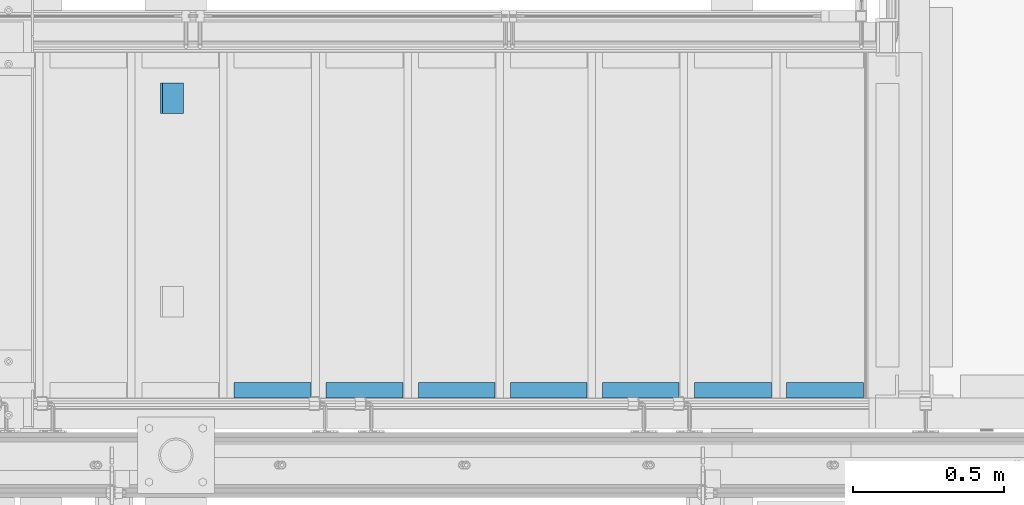
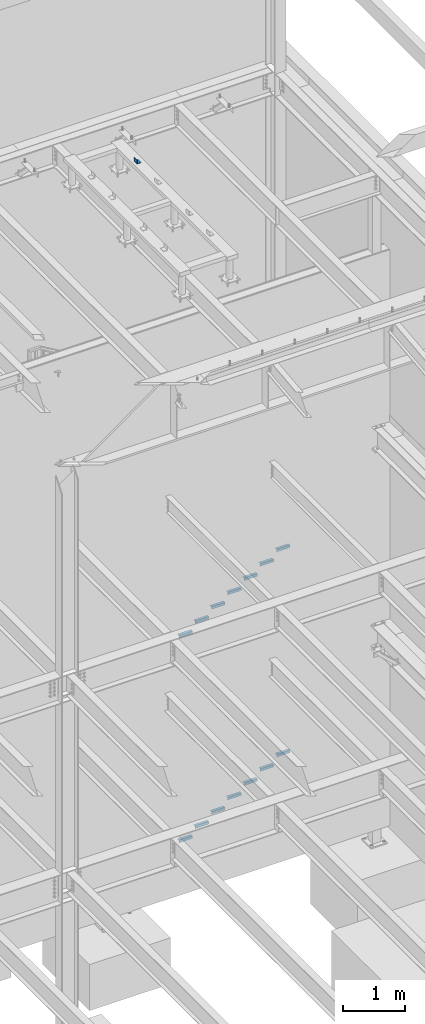
# One storey, part 914 of 1179: 15 beams, 3 elements without a shape of their own.
"""IFC2X3 building model written with IfcOpenShell, lengths in millimetres."""

from ifc_helpers import new_model, si_unit, frame, origin_with_axes, place, context, subcontext, project, spatial, faceted_brep, material, type_object, element, aggregate, save


model = new_model("IFC2X3")

# Units and contexts
model_context = context("Model", 3, precision=1e-05, world=origin_with_axes())
body_context = subcontext(model_context, "Body", "Model", "MODEL_VIEW")
ifc_project = project(units=[si_unit("LENGTHUNIT", "METRE", prefix="MILLI"), si_unit("AREAUNIT", "SQUARE_METRE"), si_unit("VOLUMEUNIT", "CUBIC_METRE"), si_unit("MASSUNIT", "GRAM", prefix="KILO"), si_unit("TIMEUNIT", "SECOND"), si_unit("PLANEANGLEUNIT", "RADIAN"), si_unit("SOLIDANGLEUNIT", "STERADIAN"), si_unit("THERMODYNAMICTEMPERATUREUNIT", "DEGREE_CELSIUS"), si_unit("LUMINOUSINTENSITYUNIT", "LUMEN")], contexts=[model_context])

# Site, building, storey
site_placement = place(None, origin_with_axes())
site = spatial("IfcSite", under=ifc_project, at=site_placement, CompositionType="ELEMENT")
building_placement = place(site_placement, origin_with_axes())
building = spatial("IfcBuilding", under=site, at=building_placement, Name="Undefined", CompositionType="ELEMENT")
storey_placement = place(building_placement, origin_with_axes())
storey = spatial("IfcBuildingStorey", under=building, at=storey_placement, Name="Undefined", CompositionType="ELEMENT", Elevation=0.0)

# Assembly, beams
assembly_1_placement = place(storey_placement, origin_with_axes())
assembly_1 = element("IfcElementAssembly", 1, at=assembly_1_placement, inside=storey, Name="STAIR", AssemblyPlace="NOTDEFINED", PredefinedType="RIGID_FRAME")
ifc_material = material(Name="STEEL/A36")
beam_type_1 = type_object("IfcBeamType", Name="L2X2X3/16", PredefinedType="NOTDEFINED")
beam_1_placement = place(assembly_1_placement, frame((22850.8130333856, 38233.3500001282, 5934.67030000019), z_axis=(0.0, 1.0, 0.0), x_axis=(-1.0, 0.0, 0.0)))
beam_1 = element("IfcBeam", 2, at=beam_1_placement, type_object=beam_type_1, material=ifc_material, Name="ANGLE", ObjectType="L2X2X3/16", context=body_context, shape_type="Brep", body=[
    faceted_brep([(0.0, 25.3999999999996, -25.4000000000015), (0.0, 25.3999999999996, 25.4000000000015), (254.0, 25.3999999999996, 25.4000000000001), (254.0, 25.3999999999996, -25.4000000000001), (0.0, 20.6374999999998, 25.4000000000015), (254.0, 20.6374999999998, 25.4000000000001), (0.0, 20.6374999999998, -20.6374999999971), (254.0, 20.6374999999998, -20.6374999999998), (0.0, -25.3999999999996, -20.6374999999971), (254.0, -25.3999999999996, -20.6374999999998), (0.0, -25.3999999999996, -25.4000000000015), (254.0, -25.3999999999996, -25.4000000000001)], [[[0, 1, 2, 3]], [[1, 4, 5, 2]], [[4, 6, 7, 5]], [[6, 8, 9, 7]], [[8, 10, 11, 9]], [[10, 0, 3, 11]], [[5, 7, 9, 11, 3, 2]], [[10, 8, 6, 4, 1, 0]]]),
])
beam_2_placement = place(assembly_1_placement, frame((22546.0130334085, 38233.3500001282, 5756.87030000019), z_axis=(0.0, 1.0, 0.0), x_axis=(-1.0, 0.0, 0.0)))
beam_2 = element("IfcBeam", 3, at=beam_2_placement, type_object=beam_type_1, material=ifc_material, Name="ANGLE", ObjectType="L2X2X3/16", context=body_context, shape_type="Brep", body=[
    faceted_brep([(0.0, 25.3999999999996, -25.4000000000015), (0.0, 25.3999999999996, 25.4000000000015), (254.0, 25.3999999999996, 25.4000000000001), (254.0, 25.3999999999996, -25.4000000000001), (0.0, 20.6374999999998, 25.4000000000015), (254.0, 20.6374999999998, 25.4000000000001), (0.0, 20.6374999999998, -20.6374999999971), (254.0, 20.6374999999998, -20.6374999999998), (0.0, -25.3999999999996, -20.6374999999971), (254.0, -25.3999999999996, -20.6374999999998), (0.0, -25.3999999999996, -25.4000000000015), (254.0, -25.3999999999996, -25.4000000000001)], [[[0, 1, 2, 3]], [[1, 4, 5, 2]], [[4, 6, 7, 5]], [[6, 8, 9, 7]], [[8, 10, 11, 9]], [[10, 0, 3, 11]], [[5, 7, 9, 11, 3, 2]], [[10, 8, 6, 4, 1, 0]]]),
])
beam_3_placement = place(assembly_1_placement, frame((22241.2130334314, 38233.3500001282, 5579.07030000019), z_axis=(0.0, 1.0, 0.0), x_axis=(-1.0, 0.0, 0.0)))
beam_3 = element("IfcBeam", 4, at=beam_3_placement, type_object=beam_type_1, material=ifc_material, Name="ANGLE", ObjectType="L2X2X3/16", context=body_context, shape_type="Brep", body=[
    faceted_brep([(0.0, 25.3999999999996, -25.4000000000015), (0.0, 25.3999999999996, 25.4000000000015), (254.0, 25.3999999999996, 25.4000000000001), (254.0, 25.3999999999996, -25.4000000000001), (0.0, 20.6374999999998, 25.4000000000015), (254.0, 20.6374999999998, 25.4000000000001), (0.0, 20.6374999999998, -20.6374999999971), (254.0, 20.6374999999998, -20.6374999999998), (0.0, -25.3999999999996, -20.6374999999971), (254.0, -25.3999999999996, -20.6374999999998), (0.0, -25.3999999999996, -25.4000000000015), (254.0, -25.3999999999996, -25.4000000000001)], [[[0, 1, 2, 3]], [[1, 4, 5, 2]], [[4, 6, 7, 5]], [[6, 8, 9, 7]], [[8, 10, 11, 9]], [[10, 0, 3, 11]], [[5, 7, 9, 11, 3, 2]], [[10, 8, 6, 4, 1, 0]]]),
])
beam_4_placement = place(assembly_1_placement, frame((21936.4130334544, 38233.3500001282, 5401.27030000019), z_axis=(0.0, 1.0, 0.0), x_axis=(-1.0, 0.0, 0.0)))
beam_4 = element("IfcBeam", 5, at=beam_4_placement, type_object=beam_type_1, material=ifc_material, Name="ANGLE", ObjectType="L2X2X3/16", context=body_context, shape_type="Brep", body=[
    faceted_brep([(0.0, 25.3999999999996, -25.4000000000015), (0.0, 25.3999999999996, 25.4000000000015), (254.0, 25.3999999999996, 25.4000000000001), (254.0, 25.3999999999996, -25.4000000000001), (0.0, 20.6374999999998, 25.4000000000015), (254.0, 20.6374999999998, 25.4000000000001), (0.0, 20.6374999999998, -20.6374999999971), (254.0, 20.6374999999998, -20.6374999999998), (0.0, -25.3999999999996, -20.6374999999971), (254.0, -25.3999999999996, -20.6374999999998), (0.0, -25.3999999999996, -25.4000000000015), (254.0, -25.3999999999996, -25.4000000000001)], [[[0, 1, 2, 3]], [[1, 4, 5, 2]], [[4, 6, 7, 5]], [[6, 8, 9, 7]], [[8, 10, 11, 9]], [[10, 0, 3, 11]], [[5, 7, 9, 11, 3, 2]], [[10, 8, 6, 4, 1, 0]]]),
])
beam_5_placement = place(assembly_1_placement, frame((21631.6130334773, 38233.3500001282, 5223.47030000019), z_axis=(0.0, 1.0, 0.0), x_axis=(-1.0, 0.0, 0.0)))
beam_5 = element("IfcBeam", 6, at=beam_5_placement, type_object=beam_type_1, material=ifc_material, Name="ANGLE", ObjectType="L2X2X3/16", context=body_context, shape_type="Brep", body=[
    faceted_brep([(0.0, 25.3999999999996, -25.4000000000015), (0.0, 25.3999999999996, 25.4000000000015), (254.0, 25.3999999999996, 25.4000000000001), (254.0, 25.3999999999996, -25.4000000000001), (0.0, 20.6374999999998, 25.4000000000015), (254.0, 20.6374999999998, 25.4000000000001), (0.0, 20.6374999999998, -20.6374999999971), (254.0, 20.6374999999998, -20.6374999999998), (0.0, -25.3999999999996, -20.6374999999971), (254.0, -25.3999999999996, -20.6374999999998), (0.0, -25.3999999999996, -25.4000000000015), (254.0, -25.3999999999996, -25.4000000000001)], [[[0, 1, 2, 3]], [[1, 4, 5, 2]], [[4, 6, 7, 5]], [[6, 8, 9, 7]], [[8, 10, 11, 9]], [[10, 0, 3, 11]], [[5, 7, 9, 11, 3, 2]], [[10, 8, 6, 4, 1, 0]]]),
])
beam_6_placement = place(assembly_1_placement, frame((21326.8130335002, 38233.3500001282, 5045.67030000019), z_axis=(0.0, 1.0, 0.0), x_axis=(-1.0, 0.0, 0.0)))
beam_6 = element("IfcBeam", 7, at=beam_6_placement, type_object=beam_type_1, material=ifc_material, Name="ANGLE", ObjectType="L2X2X3/16", context=body_context, shape_type="Brep", body=[
    faceted_brep([(0.0, 25.3999999999996, -25.4000000000015), (0.0, 25.3999999999996, 25.4000000000015), (254.0, 25.3999999999996, 25.4000000000001), (254.0, 25.3999999999996, -25.4000000000001), (0.0, 20.6374999999998, 25.4000000000015), (254.0, 20.6374999999998, 25.4000000000001), (0.0, 20.6374999999998, -20.6374999999971), (254.0, 20.6374999999998, -20.6374999999998), (0.0, -25.3999999999996, -20.6374999999971), (254.0, -25.3999999999996, -20.6374999999998), (0.0, -25.3999999999996, -25.4000000000015), (254.0, -25.3999999999996, -25.4000000000001)], [[[0, 1, 2, 3]], [[1, 4, 5, 2]], [[4, 6, 7, 5]], [[6, 8, 9, 7]], [[8, 10, 11, 9]], [[10, 0, 3, 11]], [[5, 7, 9, 11, 3, 2]], [[10, 8, 6, 4, 1, 0]]]),
])
beam_7_placement = place(assembly_1_placement, frame((21022.0130335231, 38233.3500001282, 4867.87030000019), z_axis=(0.0, 1.0, 0.0), x_axis=(-1.0, 0.0, 0.0)))
beam_7 = element("IfcBeam", 8, at=beam_7_placement, type_object=beam_type_1, material=ifc_material, Name="ANGLE", ObjectType="L2X2X3/16", context=body_context, shape_type="Brep", body=[
    faceted_brep([(0.0, 25.3999999999996, -25.4000000000015), (0.0, 25.3999999999996, 25.4000000000015), (254.0, 25.3999999999996, 25.4000000000001), (254.0, 25.3999999999996, -25.4000000000001), (0.0, 20.6374999999998, 25.4000000000015), (254.0, 20.6374999999998, 25.4000000000001), (0.0, 20.6374999999998, -20.6374999999971), (254.0, 20.6374999999998, -20.6374999999998), (0.0, -25.3999999999996, -20.6374999999971), (254.0, -25.3999999999996, -20.6374999999998), (0.0, -25.3999999999996, -25.4000000000015), (254.0, -25.3999999999996, -25.4000000000001)], [[[0, 1, 2, 3]], [[1, 4, 5, 2]], [[4, 6, 7, 5]], [[6, 8, 9, 7]], [[8, 10, 11, 9]], [[10, 0, 3, 11]], [[5, 7, 9, 11, 3, 2]], [[10, 8, 6, 4, 1, 0]]]),
])
aggregate(assembly_1, [beam_1, beam_2, beam_3, beam_4, beam_5, beam_6, beam_7])

assembly_2_placement = place(storey_placement, origin_with_axes())
assembly_2 = element("IfcElementAssembly", 9, at=assembly_2_placement, inside=storey, Name="STAIR", AssemblyPlace="NOTDEFINED", PredefinedType="RIGID_FRAME")
beam_8_placement = place(assembly_2_placement, frame((22546.06782724, 38233.3500000269, 1685.9911327928), z_axis=(0.0, 1.0, 0.0), x_axis=(-1.0, 0.0, 0.0)))
beam_8 = element("IfcBeam", 10, at=beam_8_placement, type_object=beam_type_1, material=ifc_material, Name="ANGLE", ObjectType="L2X2X3/16", context=body_context, shape_type="Brep", body=[
    faceted_brep([(0.0, 25.3999999999996, -25.4000000000015), (0.0, 25.3999999999996, 25.4000000000015), (254.0, 25.3999999999996, 25.4000000000001), (254.0, 25.3999999999996, -25.4000000000001), (0.0, 20.6374999999998, 25.4000000000015), (254.0, 20.6374999999998, 25.4000000000001), (0.0, 20.6374999999998, -20.6374999999971), (254.0, 20.6374999999998, -20.6374999999998), (0.0, -25.3999999999996, -20.6374999999971), (254.0, -25.3999999999996, -20.6374999999998), (0.0, -25.3999999999996, -25.4000000000015), (254.0, -25.3999999999996, -25.4000000000001)], [[[0, 1, 2, 3]], [[1, 4, 5, 2]], [[4, 6, 7, 5]], [[6, 8, 9, 7]], [[8, 10, 11, 9]], [[10, 0, 3, 11]], [[5, 7, 9, 11, 3, 2]], [[10, 8, 6, 4, 1, 0]]]),
])
beam_9_placement = place(assembly_2_placement, frame((22241.2678272132, 38233.3500000282, 1509.5140495136), z_axis=(0.0, 1.0, 0.0), x_axis=(-1.0, 0.0, 0.0)))
beam_9 = element("IfcBeam", 11, at=beam_9_placement, type_object=beam_type_1, material=ifc_material, Name="ANGLE", ObjectType="L2X2X3/16", context=body_context, shape_type="Brep", body=[
    faceted_brep([(0.0, 25.3999999999996, -25.4000000000015), (0.0, 25.3999999999996, 25.4000000000015), (254.0, 25.3999999999996, 25.4000000000001), (254.0, 25.3999999999996, -25.4000000000001), (0.0, 20.6374999999998, 25.4000000000015), (254.0, 20.6374999999998, 25.4000000000001), (0.0, 20.6374999999998, -20.6374999999971), (254.0, 20.6374999999998, -20.6374999999998), (0.0, -25.3999999999996, -20.6374999999971), (254.0, -25.3999999999996, -20.6374999999998), (0.0, -25.3999999999996, -25.4000000000015), (254.0, -25.3999999999996, -25.4000000000001)], [[[0, 1, 2, 3]], [[1, 4, 5, 2]], [[4, 6, 7, 5]], [[6, 8, 9, 7]], [[8, 10, 11, 9]], [[10, 0, 3, 11]], [[5, 7, 9, 11, 3, 2]], [[10, 8, 6, 4, 1, 0]]]),
])
beam_10_placement = place(assembly_2_placement, frame((21936.4678271865, 38233.3500000295, 1333.0369662344), z_axis=(0.0, 1.0, 0.0), x_axis=(-1.0, 0.0, 0.0)))
beam_10 = element("IfcBeam", 12, at=beam_10_placement, type_object=beam_type_1, material=ifc_material, Name="ANGLE", ObjectType="L2X2X3/16", context=body_context, shape_type="Brep", body=[
    faceted_brep([(0.0, 25.3999999999996, -25.4000000000015), (0.0, 25.3999999999996, 25.4000000000015), (254.0, 25.3999999999996, 25.4000000000001), (254.0, 25.3999999999996, -25.4000000000001), (0.0, 20.6374999999998, 25.4000000000015), (254.0, 20.6374999999998, 25.4000000000001), (0.0, 20.6374999999998, -20.6374999999971), (254.0, 20.6374999999998, -20.6374999999998), (0.0, -25.3999999999996, -20.6374999999971), (254.0, -25.3999999999996, -20.6374999999998), (0.0, -25.3999999999996, -25.4000000000015), (254.0, -25.3999999999996, -25.4000000000001)], [[[0, 1, 2, 3]], [[1, 4, 5, 2]], [[4, 6, 7, 5]], [[6, 8, 9, 7]], [[8, 10, 11, 9]], [[10, 0, 3, 11]], [[5, 7, 9, 11, 3, 2]], [[10, 8, 6, 4, 1, 0]]]),
])
beam_11_placement = place(assembly_2_placement, frame((22850.8678272667, 38233.3500000256, 1862.468216072), z_axis=(0.0, 1.0, 0.0), x_axis=(-1.0, 0.0, 0.0)))
beam_11 = element("IfcBeam", 13, at=beam_11_placement, type_object=beam_type_1, material=ifc_material, Name="ANGLE", ObjectType="L2X2X3/16", context=body_context, shape_type="Brep", body=[
    faceted_brep([(0.0, 25.3999999999996, -25.4000000000015), (0.0, 25.3999999999996, 25.4000000000015), (254.0, 25.3999999999996, 25.4000000000001), (254.0, 25.3999999999996, -25.4000000000001), (0.0, 20.6374999999998, 25.4000000000015), (254.0, 20.6374999999998, 25.4000000000001), (0.0, 20.6374999999998, -20.6374999999971), (254.0, 20.6374999999998, -20.6374999999998), (0.0, -25.3999999999996, -20.6374999999971), (254.0, -25.3999999999996, -20.6374999999998), (0.0, -25.3999999999996, -25.4000000000015), (254.0, -25.3999999999996, -25.4000000000001)], [[[0, 1, 2, 3]], [[1, 4, 5, 2]], [[4, 6, 7, 5]], [[6, 8, 9, 7]], [[8, 10, 11, 9]], [[10, 0, 3, 11]], [[5, 7, 9, 11, 3, 2]], [[10, 8, 6, 4, 1, 0]]]),
])
beam_12_placement = place(assembly_2_placement, frame((21631.6678271597, 38233.3500000307, 1156.5598829552), z_axis=(0.0, 1.0, 0.0), x_axis=(-1.0, 0.0, 0.0)))
beam_12 = element("IfcBeam", 14, at=beam_12_placement, type_object=beam_type_1, material=ifc_material, Name="ANGLE", ObjectType="L2X2X3/16", context=body_context, shape_type="Brep", body=[
    faceted_brep([(0.0, 25.3999999999996, -25.4000000000015), (0.0, 25.3999999999996, 25.4000000000015), (254.0, 25.3999999999996, 25.4000000000001), (254.0, 25.3999999999996, -25.4000000000001), (0.0, 20.6374999999998, 25.4000000000015), (254.0, 20.6374999999998, 25.4000000000001), (0.0, 20.6374999999998, -20.6374999999971), (254.0, 20.6374999999998, -20.6374999999998), (0.0, -25.3999999999996, -20.6374999999971), (254.0, -25.3999999999996, -20.6374999999998), (0.0, -25.3999999999996, -25.4000000000015), (254.0, -25.3999999999996, -25.4000000000001)], [[[0, 1, 2, 3]], [[1, 4, 5, 2]], [[4, 6, 7, 5]], [[6, 8, 9, 7]], [[8, 10, 11, 9]], [[10, 0, 3, 11]], [[5, 7, 9, 11, 3, 2]], [[10, 8, 6, 4, 1, 0]]]),
])
beam_13_placement = place(assembly_2_placement, frame((21326.8678271329, 38233.350000032, 980.082799676004), z_axis=(0.0, 1.0, 0.0), x_axis=(-1.0, 0.0, 0.0)))
beam_13 = element("IfcBeam", 15, at=beam_13_placement, type_object=beam_type_1, material=ifc_material, Name="ANGLE", ObjectType="L2X2X3/16", context=body_context, shape_type="Brep", body=[
    faceted_brep([(0.0, 25.3999999999996, -25.4000000000015), (0.0, 25.3999999999996, 25.4000000000015), (254.0, 25.3999999999996, 25.4000000000001), (254.0, 25.3999999999996, -25.4000000000001), (0.0, 20.6374999999998, 25.4000000000015), (254.0, 20.6374999999998, 25.4000000000001), (0.0, 20.6374999999998, -20.6374999999971), (254.0, 20.6374999999998, -20.6374999999998), (0.0, -25.3999999999996, -20.6374999999971), (254.0, -25.3999999999996, -20.6374999999998), (0.0, -25.3999999999996, -25.4000000000015), (254.0, -25.3999999999996, -25.4000000000001)], [[[0, 1, 2, 3]], [[1, 4, 5, 2]], [[4, 6, 7, 5]], [[6, 8, 9, 7]], [[8, 10, 11, 9]], [[10, 0, 3, 11]], [[5, 7, 9, 11, 3, 2]], [[10, 8, 6, 4, 1, 0]]]),
])
beam_14_placement = place(assembly_2_placement, frame((21022.0678271062, 38233.3500000333, 803.605716396806), z_axis=(0.0, 1.0, 0.0), x_axis=(-1.0, 0.0, 0.0)))
beam_14 = element("IfcBeam", 16, at=beam_14_placement, type_object=beam_type_1, material=ifc_material, Name="ANGLE", ObjectType="L2X2X3/16", context=body_context, shape_type="Brep", body=[
    faceted_brep([(0.0, 25.3999999999996, -25.4000000000015), (0.0, 25.3999999999996, 25.4000000000015), (254.0, 25.3999999999996, 25.4000000000001), (254.0, 25.3999999999996, -25.4000000000001), (0.0, 20.6374999999998, 25.4000000000015), (254.0, 20.6374999999998, 25.4000000000001), (0.0, 20.6374999999998, -20.6374999999971), (254.0, 20.6374999999998, -20.6374999999998), (0.0, -25.3999999999996, -20.6374999999971), (254.0, -25.3999999999996, -20.6374999999998), (0.0, -25.3999999999996, -25.4000000000015), (254.0, -25.3999999999996, -25.4000000000001)], [[[0, 1, 2, 3]], [[1, 4, 5, 2]], [[4, 6, 7, 5]], [[6, 8, 9, 7]], [[8, 10, 11, 9]], [[10, 0, 3, 11]], [[5, 7, 9, 11, 3, 2]], [[10, 8, 6, 4, 1, 0]]]),
])
aggregate(assembly_2, [beam_8, beam_9, beam_10, beam_11, beam_12, beam_13, beam_14])

# Assembly, beam
assembly_3_placement = place(storey_placement, origin_with_axes())
assembly_3 = element("IfcElementAssembly", 17, at=assembly_3_placement, inside=storey, Name="FRAME", AssemblyPlace="NOTDEFINED", PredefinedType="RIGID_FRAME")
beam_type_2 = type_object("IfcBeamType", Name="L3X3X1/4", PredefinedType="NOTDEFINED")
beam_15_placement = place(assembly_3_placement, frame((20562.8875, 39148.6225542222, 13798.55), z_axis=(0.0, 0.0, 1.0), x_axis=(0.0, 1.0, 0.0)))
beam_15 = element("IfcBeam", 18, at=beam_15_placement, type_object=beam_type_2, material=ifc_material, Name="ANGLE", ObjectType="L3X3X1/4", context=body_context, shape_type="Brep", body=[
    faceted_brep([(0.0, 38.0999999999985, -38.0999999999999), (0.0, 38.0999999999985, 38.0999999999999), (101.600000000035, 38.0999999999985, 38.099999999994), (101.599999999962, 38.0999999999985, -38.1000000000058), (0.0, 31.75, 38.1000000000004), (101.600000000035, 31.75, 38.099999999994), (0.0, 31.75, -31.75), (101.599999999969, 31.75, -31.7500000000064), (0.0, -38.0999999999985, -31.75), (101.599999999969, -38.0999999999985, -31.7500000000064), (0.0, -38.0999999999985, -38.0999999999999), (101.599999999962, -38.0999999999985, -38.1000000000058)], [[[0, 1, 2, 3]], [[1, 4, 5, 2]], [[4, 6, 7, 5]], [[6, 8, 9, 7]], [[8, 10, 11, 9]], [[10, 0, 3, 11]], [[5, 7, 9, 11, 3, 2]], [[10, 8, 6, 4, 1, 0]]]),
])
aggregate(assembly_3, [beam_15])

save(model, "model.ifc")
